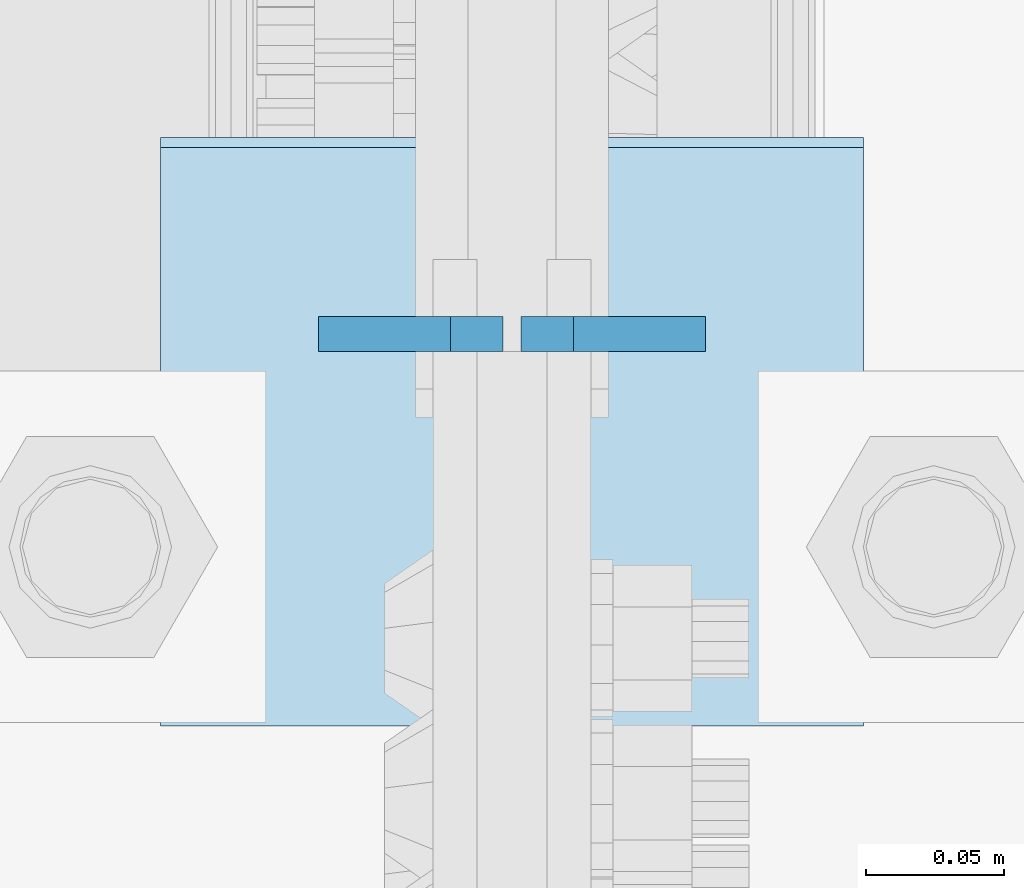
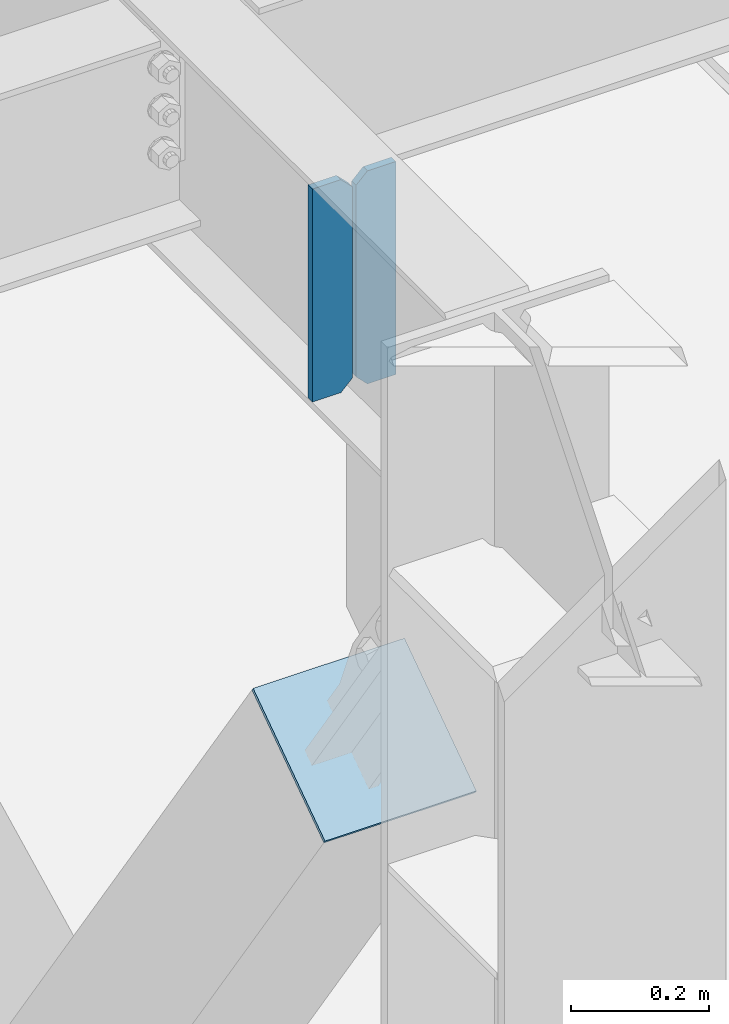
# One storey, part 3122 of 3843: 3 plates, 2 elements without a shape of their own.
"""IFC2X3 building model written with IfcOpenShell, lengths in millimetres."""

from ifc_helpers import new_model, si_unit, frame, origin_with_axes, place, context, subcontext, project, spatial, faceted_brep, material, type_object, element, aggregate, save


model = new_model("IFC2X3")

# Units and contexts
model_context = context("Model", 3, precision=1e-05, world=origin_with_axes())
body_context = subcontext(model_context, "Body", "Model", "MODEL_VIEW")
ifc_project = project(units=[si_unit("LENGTHUNIT", "METRE", prefix="MILLI"), si_unit("AREAUNIT", "SQUARE_METRE"), si_unit("VOLUMEUNIT", "CUBIC_METRE"), si_unit("MASSUNIT", "GRAM", prefix="KILO"), si_unit("TIMEUNIT", "SECOND"), si_unit("PLANEANGLEUNIT", "RADIAN"), si_unit("SOLIDANGLEUNIT", "STERADIAN"), si_unit("THERMODYNAMICTEMPERATUREUNIT", "DEGREE_CELSIUS"), si_unit("LUMINOUSINTENSITYUNIT", "LUMEN")], contexts=[model_context])

# Site, building, storey
site_placement = place(None, origin_with_axes())
site = spatial("IfcSite", under=ifc_project, at=site_placement, CompositionType="ELEMENT")
building_placement = place(site_placement, origin_with_axes())
building = spatial("IfcBuilding", under=site, at=building_placement, Name="Undefined", CompositionType="ELEMENT")
storey_placement = place(building_placement, origin_with_axes())
storey = spatial("IfcBuildingStorey", under=building, at=storey_placement, Name="Undefined", CompositionType="ELEMENT", Elevation=0.0)

# Assembly, plates
assembly_1_placement = place(storey_placement, origin_with_axes())
assembly_1 = element("IfcElementAssembly", 1, at=assembly_1_placement, inside=storey, Name="BEAM", AssemblyPlace="NOTDEFINED", PredefinedType="RIGID_FRAME")
ifc_material_1 = material(Name="STEEL/A572-50")
plate_type_1 = type_object("IfcPlateType", PredefinedType="NOTDEFINED")
plate_1_placement = place(assembly_1_placement, frame((55927.625, 20892.2889674979, 42078.275), z_axis=(-1.0, 0.0, 0.0), x_axis=(0.0, 0.0, 1.0)))
plate_1 = element("IfcPlate", 2, at=plate_1_placement, type_object=plate_type_1, material=ifc_material_1, Name="CB_BEAM", context=body_context, shape_type="Brep", body=[
    faceted_brep([(0.0, -6.34999999999854, 19.0499992370605), (0.0, -6.34999999999854, 66.6750000000029), (0.0, 6.34999999999854, 66.6750000000029), (0.0, 6.34999999999854, 19.0499992370605), (377.825000000004, -6.34999999999854, 66.6749999999956), (377.825000000004, 6.34999999999854, 66.6749999999956), (377.825000000004, -6.34999999999854, 19.0499992370533), (377.825000000004, 6.34999999999854, 19.0499992370533), (358.775000762944, -6.34999999999854, -7.27595761418343e-12), (358.775000762944, 6.34999999999854, -7.27595761418343e-12), (19.0499992370605, -6.34999999999854, 0.0), (19.0499992370605, 6.34999999999854, 0.0)], [[[0, 1, 2, 3]], [[1, 4, 5, 2]], [[4, 6, 7, 5]], [[6, 8, 9, 7]], [[8, 10, 11, 9]], [[10, 0, 3, 11]], [[5, 7, 9, 11, 3, 2]], [[10, 8, 6, 4, 1, 0]]]),
])
plate_2_placement = place(assembly_1_placement, frame((55933.975, 20892.2889674979, 42078.275), z_axis=(1.0, 0.0, 0.0), x_axis=(0.0, 0.0, 1.0)))
plate_2 = element("IfcPlate", 3, at=plate_2_placement, type_object=plate_type_1, material=ifc_material_1, Name="CB_BEAM", context=body_context, shape_type="Brep", body=[
    faceted_brep([(0.0, -6.34999999999854, 19.0499992370605), (0.0, -6.34999999999854, 66.6750000000029), (0.0, 6.34999999999854, 66.6750000000029), (0.0, 6.34999999999854, 19.0499992370605), (377.825000000004, -6.34999999999854, 66.6749999999956), (377.825000000004, 6.34999999999854, 66.6749999999956), (377.825000000004, -6.34999999999854, 19.0499992370533), (377.825000000004, 6.34999999999854, 19.0499992370533), (358.775000762944, -6.34999999999854, -7.27595761418343e-12), (358.775000762944, 6.34999999999854, -7.27595761418343e-12), (19.0499992370605, -6.34999999999854, 0.0), (19.0499992370605, 6.34999999999854, 0.0)], [[[0, 1, 2, 3]], [[1, 4, 5, 2]], [[4, 6, 7, 5]], [[6, 8, 9, 7]], [[8, 10, 11, 9]], [[10, 0, 3, 11]], [[5, 7, 9, 11, 3, 2]], [[10, 8, 6, 4, 1, 0]]]),
])
aggregate(assembly_1, [plate_1, plate_2])

# Assembly, plate
assembly_2_placement = place(storey_placement, origin_with_axes())
assembly_2 = element("IfcElementAssembly", 4, at=assembly_2_placement, inside=storey, Name="Plate", AssemblyPlace="NOTDEFINED", PredefinedType="RIGID_FRAME")
ifc_material_2 = material(Name="STEEL/A36")
plate_type_2 = type_object("IfcPlateType", PredefinedType="NOTDEFINED")
plate_3_placement = place(assembly_2_placement, frame((55803.8, 20752.3794351635, 41399.0846702118), z_axis=(0.0, 0.822893061718405, 0.568196276805568), x_axis=(1.0, 0.0, 0.0)))
plate_3 = element("IfcPlate", 5, at=plate_3_placement, type_object=plate_type_2, material=ifc_material_2, Name="Plate", context=body_context, shape_type="Brep", body=[
    faceted_brep([(0.0, -3.17499999999927, 0.0), (0.0, -3.17499999965185, 254.000000005151), (0.0, 3.17500000035216, 254.000000005166), (0.0, 3.17499999999927, 0.0), (254.0, -3.17499999965185, 254.000000005151), (254.0, 3.17500000035216, 254.000000005166), (254.0, -3.17500000000291, 0.0), (254.0, 3.17499999999927, 1.45519152283669e-11)], [[[0, 1, 2, 3]], [[1, 4, 5, 2]], [[4, 6, 7, 5]], [[6, 0, 3, 7]], [[5, 7, 3, 2]], [[6, 4, 1, 0]]]),
])
aggregate(assembly_2, [plate_3])

save(model, "model.ifc")
